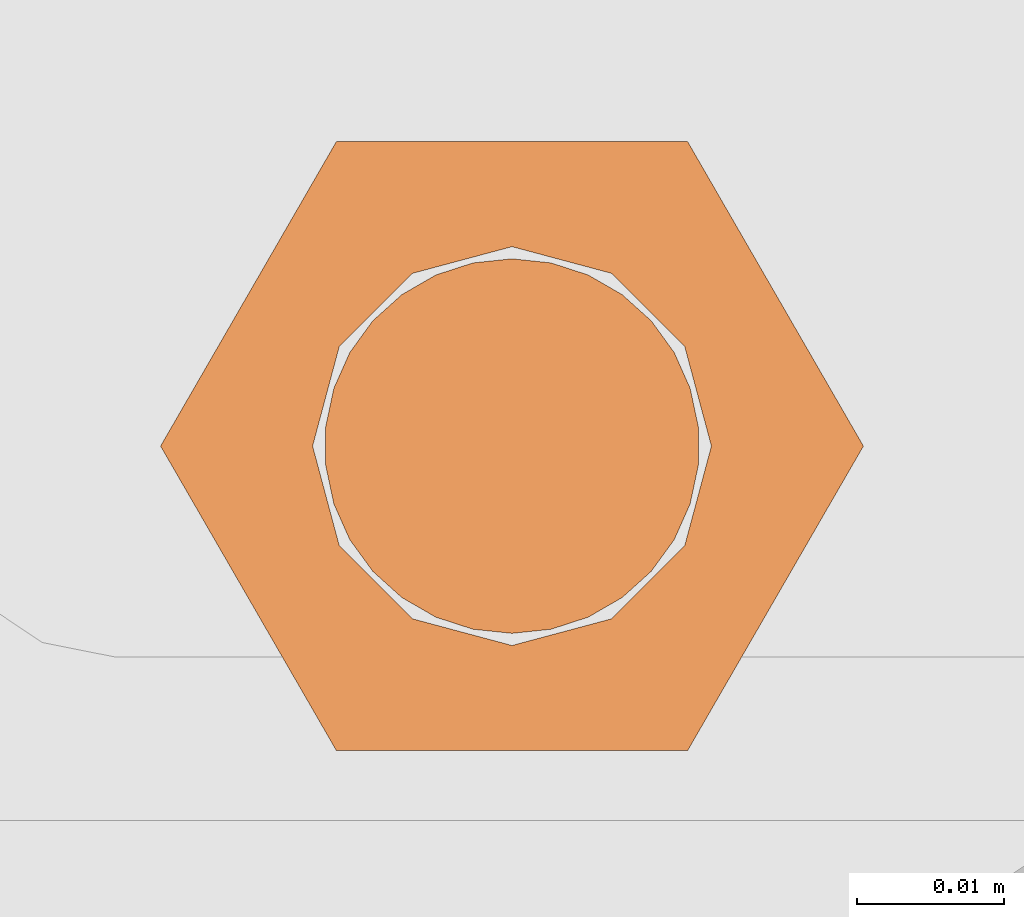
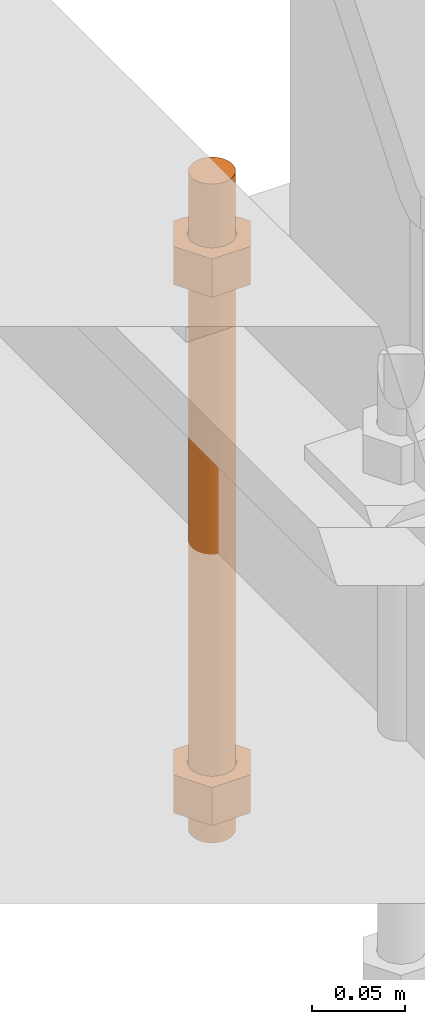
# One storey, part 31 of 89: 1 proxy.
"""IFC4 building model written with IfcOpenShell, lengths in feet."""

from ifc_helpers import new_model, entity, si_unit, converted_unit, derived_unit, direction, frame, origin, place, context, subcontext, project, spatial, faceted_brep, source, transform, mapped, material, constituent, constituent_set, type_object, type_shapes, element, save


model = new_model("IFC4")

# Units and contexts
model_context = context("Model", 3, precision=0.0001, world=origin(), true_north=direction((6.12303176911189e-17, 1.0)))
body_context = subcontext(model_context, "Body", "Model", "MODEL_VIEW")
ifc_project = project(units=[converted_unit("LENGTHUNIT", "FOOT", entity("IfcRatioMeasure", 0.3048), si_unit("LENGTHUNIT", "METRE"), dimensions=[1, 0, 0, 0, 0, 0, 0]), converted_unit("AREAUNIT", "SQUARE FOOT", entity("IfcRatioMeasure", 0.09290304), si_unit("AREAUNIT", "SQUARE_METRE"), dimensions=[2, 0, 0, 0, 0, 0, 0]), converted_unit("VOLUMEUNIT", "CUBIC FOOT", entity("IfcRatioMeasure", 0.028316846592), si_unit("VOLUMEUNIT", "CUBIC_METRE"), dimensions=[3, 0, 0, 0, 0, 0, 0]), si_unit("PLANEANGLEUNIT", "RADIAN"), si_unit("MASSUNIT", "GRAM", prefix="KILO"), derived_unit("MASSDENSITYUNIT", [(si_unit("MASSUNIT", "GRAM", prefix="KILO"), 1), (si_unit("LENGTHUNIT", "METRE"), -3)]), derived_unit("MOMENTOFINERTIAUNIT", [(si_unit("LENGTHUNIT", "METRE"), 4)]), si_unit("TIMEUNIT", "SECOND"), si_unit("FREQUENCYUNIT", "HERTZ"), si_unit("THERMODYNAMICTEMPERATUREUNIT", "DEGREE_CELSIUS"), derived_unit("THERMALTRANSMITTANCEUNIT", [(si_unit("MASSUNIT", "GRAM", prefix="KILO"), 1), (si_unit("THERMODYNAMICTEMPERATUREUNIT", "KELVIN"), -1), (si_unit("TIMEUNIT", "SECOND"), -3)]), derived_unit("VOLUMETRICFLOWRATEUNIT", [(si_unit("LENGTHUNIT", "METRE"), 3), (si_unit("TIMEUNIT", "SECOND"), -1)]), si_unit("ELECTRICCURRENTUNIT", "AMPERE"), si_unit("ELECTRICVOLTAGEUNIT", "VOLT"), si_unit("POWERUNIT", "WATT"), si_unit("FORCEUNIT", "NEWTON"), si_unit("ILLUMINANCEUNIT", "LUX"), si_unit("LUMINOUSFLUXUNIT", "LUMEN"), si_unit("LUMINOUSINTENSITYUNIT", "CANDELA"), derived_unit("USERDEFINED", [(si_unit("MASSUNIT", "GRAM", prefix="KILO"), -1), (si_unit("LENGTHUNIT", "METRE"), -2), (si_unit("TIMEUNIT", "SECOND"), 3), (si_unit("LUMINOUSFLUXUNIT", "LUMEN"), 1)]), derived_unit("LINEARVELOCITYUNIT", [(si_unit("LENGTHUNIT", "METRE"), 1), (si_unit("TIMEUNIT", "SECOND"), -1)]), si_unit("PRESSUREUNIT", "PASCAL"), derived_unit("USERDEFINED", [(si_unit("LENGTHUNIT", "METRE"), -2), (si_unit("MASSUNIT", "GRAM", prefix="KILO"), 1), (si_unit("TIMEUNIT", "SECOND"), -2)]), derived_unit("LINEARFORCEUNIT", [(si_unit("MASSUNIT", "GRAM", prefix="KILO"), 1), (si_unit("LENGTHUNIT", "METRE"), 1), (si_unit("TIMEUNIT", "SECOND"), -2), (si_unit("LENGTHUNIT", "METRE"), -1)]), derived_unit("PLANARFORCEUNIT", [(si_unit("MASSUNIT", "GRAM", prefix="KILO"), 1), (si_unit("LENGTHUNIT", "METRE"), 1), (si_unit("TIMEUNIT", "SECOND"), -2), (si_unit("LENGTHUNIT", "METRE"), -2)])], contexts=[model_context])

# Site, building, storey
site_placement = place(None, origin())
site = spatial("IfcSite", under=ifc_project, at=site_placement, CompositionType="ELEMENT")
building_placement = place(site_placement, frame((-472.238160486, -49.138065117, 0.0)))
building = spatial("IfcBuilding", under=site, at=building_placement, CompositionType="ELEMENT")
storey_placement = place(building_placement, origin())
storey = spatial("IfcBuildingStorey", under=building, at=storey_placement, Name="Level 1", CompositionType="ELEMENT", Elevation=0.0)

# Proxy
ifc_material_1 = material(Name="Color 7721", Category="Materials")
ifc_constituent_1 = constituent(ifc_material_1, Name="Color 7721", Category="Materials")
ifc_material_2 = material(Name="Color 7720", Category="Materials")
ifc_constituent_2 = constituent(ifc_material_2, Name="Color 7720", Category="Materials")
ifc_constituent_set = constituent_set(constituents=[ifc_constituent_1, ifc_constituent_2])
building_element_proxy_type = type_object("IfcBuildingElementProxyType", Name="rb2", PredefinedType="NOTDEFINED", material=ifc_material_1)
shared_shape = source(origin(), body_context, "Body", "Brep", [
    faceted_brep([(0.122545547339286, 0.0677083333333712, 0.0626666666666664), (0.156365697905557, 0.0677083333333712, 0.0626666666666664), (0.11727427342916, 0.135416666666742, 0.0626666666666664), (0.0390914244764247, 0.135416666666742, 0.0626666666666664), (0.0, 0.0677083333333712, 0.0626666666666664), (0.0338201505662994, 0.0677083333333712, 0.0626666666666664), (0.0397636251696838, 0.089889682526632, 0.0626666666666664), (0.0560014997595601, 0.106127557116452, 0.0626666666666664), (0.0781828489527925, 0.112071031719893, 0.0626666666666664), (0.100364198146025, 0.106127557116452, 0.0626666666666664), (0.116602072735901, 0.089889682526632, 0.0626666666666664), (0.11727427342916, 0.0, 0.0626666666666664), (0.0390914244764247, 0.0, 0.0626666666666664), (0.0397636251696838, 0.0455269841401105, 0.0626666666666664), (0.0560014997595601, 0.029289109550291, 0.0626666666666664), (0.0781828489527925, 0.0233456349468497, 0.0626666666666664), (0.100364198146025, 0.029289109550291, 0.0626666666666664), (0.116602072735901, 0.0455269841401105, 0.0626666666666664), (0.0, 0.0677083333333712, 0.144697916666667), (0.0390914244763962, 0.135416666666742, 0.144697916666667), (0.11727427342916, 0.135416666666742, 0.144697916666667), (0.156365697905528, 0.0677083333333712, 0.144697916666667), (0.117274273429189, 0.0, 0.144697916666667), (0.0390914244764247, 0.0, 0.144697916666667), (0.122545547339286, 0.0677083333333712, 0.144697916666666), (0.0338201505662994, 0.0677083333333712, 0.144697916666666), (0.0397636251696838, 0.0455269841401105, 0.144697916666666), (0.0560014997595601, 0.029289109550291, 0.144697916666666), (0.0781828489527925, 0.0233456349468497, 0.144697916666666), (0.100364198146025, 0.029289109550291, 0.144697916666666), (0.116602072735901, 0.0455269841401105, 0.144697916666666), (0.0397636251696838, 0.089889682526632, 0.144697916666666), (0.0560014997595601, 0.106127557116452, 0.144697916666666), (0.0781828489527925, 0.112071031719893, 0.144697916666666), (0.100364198146025, 0.106127557116452, 0.144697916666666), (0.116602072735901, 0.089889682526632, 0.144697916666666)], [[[0, 1, 2, 3, 4, 5, 6, 7, 8, 9, 10]], [[1, 11, 12, 4, 5, 13, 14, 15, 16, 17, 0]], [[4, 18, 19, 3]], [[3, 19, 20, 2]], [[2, 20, 21, 1]], [[1, 21, 22, 11]], [[11, 22, 23, 12]], [[12, 23, 18, 4]], [[24, 21, 22, 23, 18, 25, 26, 27, 28, 29, 30]], [[21, 20, 19, 18, 25, 31, 32, 33, 34, 35, 24]], [[25, 5, 6, 31]], [[31, 6, 7, 32]], [[32, 7, 8, 33]], [[33, 8, 9, 34]], [[34, 9, 10, 35]], [[35, 10, 0, 24]], [[24, 0, 17, 30]], [[30, 17, 16, 29]], [[29, 16, 15, 28]], [[28, 15, 14, 27]], [[27, 14, 13, 26]], [[26, 13, 5, 25]]]),
    faceted_brep([(0.0338201505662994, 0.0677083333333712, 1.28108333333333), (0.0, 0.0677083333333712, 1.28108333333333), (0.0390914244764247, 0.135416666666742, 1.28108333333333), (0.11727427342916, 0.135416666666742, 1.28108333333333), (0.156365697905557, 0.0677083333333712, 1.28108333333333), (0.122545547339286, 0.0677083333333712, 1.28108333333333), (0.116602072735901, 0.089889682526632, 1.28108333333333), (0.100364198146025, 0.106127557116452, 1.28108333333333), (0.0781828489527925, 0.112071031719893, 1.28108333333333), (0.0560014997595601, 0.106127557116452, 1.28108333333333), (0.0397636251696838, 0.089889682526632, 1.28108333333333), (0.0390914244764247, 0.0, 1.28108333333333), (0.11727427342916, 0.0, 1.28108333333333), (0.116602072735901, 0.0455269841401105, 1.28108333333333), (0.100364198146025, 0.029289109550291, 1.28108333333333), (0.0781828489527925, 0.0233456349468497, 1.28108333333333), (0.0560014997595601, 0.029289109550291, 1.28108333333333), (0.0397636251696838, 0.0455269841401105, 1.28108333333333), (0.156365697905585, 0.0677083333333712, 1.19905208333333), (0.117274273429189, 0.135416666666742, 1.19905208333333), (0.0390914244764247, 0.135416666666742, 1.19905208333333), (0.0, 0.0677083333333712, 1.19905208333333), (0.0390914244763962, 0.0, 1.19905208333333), (0.11727427342916, 0.0, 1.19905208333333), (0.0338201505662994, 0.0677083333333712, 1.19905208333333), (0.122545547339286, 0.0677083333333712, 1.19905208333333), (0.116602072735901, 0.0455269841401105, 1.19905208333333), (0.100364198146025, 0.029289109550291, 1.19905208333333), (0.0781828489527925, 0.0233456349468497, 1.19905208333333), (0.0560014997595601, 0.029289109550291, 1.19905208333333), (0.0397636251696838, 0.0455269841401105, 1.19905208333333), (0.116602072735901, 0.089889682526632, 1.19905208333333), (0.100364198146025, 0.106127557116452, 1.19905208333333), (0.0781828489527925, 0.112071031719893, 1.19905208333333), (0.0560014997595601, 0.106127557116452, 1.19905208333333), (0.0397636251696838, 0.089889682526632, 1.19905208333333)], [[[0, 1, 2, 3, 4, 5, 6, 7, 8, 9, 10]], [[1, 11, 12, 4, 5, 13, 14, 15, 16, 17, 0]], [[4, 18, 19, 3]], [[3, 19, 20, 2]], [[2, 20, 21, 1]], [[1, 21, 22, 11]], [[11, 22, 23, 12]], [[12, 23, 18, 4]], [[24, 21, 22, 23, 18, 25, 26, 27, 28, 29, 30]], [[21, 20, 19, 18, 25, 31, 32, 33, 34, 35, 24]], [[25, 5, 6, 31]], [[31, 6, 7, 32]], [[32, 7, 8, 33]], [[33, 8, 9, 34]], [[34, 9, 10, 35]], [[35, 10, 0, 24]], [[24, 0, 17, 30]], [[30, 17, 16, 29]], [[29, 16, 15, 28]], [[28, 15, 14, 27]], [[27, 14, 13, 26]], [[26, 13, 5, 25]]]),
    faceted_brep([(0.0781828489527925, 0.0260416666667425, 0.0), (0.0695198618353743, 0.0269521833027966, 0.0), (0.0612354888246216, 0.029643939264929, 0.0), (0.0536917967739328, 0.0339992919010683, 0.0), (0.0472184812245757, 0.0398278914017283, 0.0), (0.0420984571284464, 0.046875, 0.0), (0.0385554941071575, 0.0548326252344395, 0.0), (0.0367444366457903, 0.0633529806972319, 0.0), (0.0367444366457903, 0.0720636859695105, 0.0), (0.0385554941071575, 0.0805840414323029, 0.0), (0.0420984571284464, 0.0885416666667425, 0.0), (0.0472184812245757, 0.0955887752650142, 0.0), (0.0536917967739328, 0.101417374765674, 0.0), (0.0612354888246216, 0.105772727401813, 0.0), (0.0695198618353743, 0.108464483363946, 0.0), (0.0781828489527925, 0.109375, 0.0), (0.0868458360702107, 0.108464483363946, 0.0), (0.0951302090809634, 0.105772727401813, 0.0), (0.102673901131652, 0.101417374765674, 0.0), (0.109147216681009, 0.0955887752650142, 0.0), (0.114267240777139, 0.0885416666667425, 0.0), (0.117810203798427, 0.0805840414323029, 0.0), (0.119621261259795, 0.0720636859695105, 0.0), (0.119621261259795, 0.0633529806972319, 0.0), (0.117810203798427, 0.0548326252344395, 0.0), (0.114267240777139, 0.046875, 0.0), (0.109147216681009, 0.0398278914017283, 0.0), (0.102673901131652, 0.0339992919010683, 0.0), (0.0951302090809634, 0.029643939264929, 0.0), (0.0868458360702107, 0.0269521833027966, 0.0), (0.0868458360702107, 0.0269521833027966, 1.41666666666667), (0.0951302090809634, 0.029643939264929, 1.41666666666667), (0.102673901131652, 0.0339992919010683, 1.41666666666667), (0.109147216681009, 0.0398278914017283, 1.41666666666667), (0.114267240777139, 0.046875, 1.41666666666667), (0.117810203798427, 0.0548326252344395, 1.41666666666667), (0.119621261259795, 0.0633529806972319, 1.41666666666667), (0.119621261259795, 0.0720636859695105, 1.41666666666667), (0.117810203798427, 0.0805840414323029, 1.41666666666667), (0.114267240777139, 0.0885416666667425, 1.41666666666667), (0.109147216681009, 0.0955887752650142, 1.41666666666667), (0.102673901131652, 0.101417374765674, 1.41666666666667), (0.0951302090809634, 0.105772727401813, 1.41666666666667), (0.0868458360702107, 0.108464483363946, 1.41666666666667), (0.0781828489527925, 0.109375, 1.41666666666667), (0.0695198618353743, 0.108464483363946, 1.41666666666667), (0.0612354888246216, 0.105772727401813, 1.41666666666667), (0.0536917967739328, 0.101417374765674, 1.41666666666667), (0.0472184812245757, 0.0955887752650142, 1.41666666666667), (0.0420984571284464, 0.0885416666667425, 1.41666666666667), (0.0385554941071575, 0.0805840414323029, 1.41666666666667), (0.0367444366457903, 0.0720636859695105, 1.41666666666667), (0.0367444366457903, 0.0633529806972319, 1.41666666666667), (0.0385554941071575, 0.0548326252344395, 1.41666666666667), (0.0420984571284464, 0.046875, 1.41666666666667), (0.0472184812245757, 0.0398278914017283, 1.41666666666667), (0.0536917967739328, 0.0339992919010683, 1.41666666666667), (0.0612354888246216, 0.029643939264929, 1.41666666666667), (0.0695198618353743, 0.0269521833027966, 1.41666666666667), (0.0781828489527925, 0.0260416666667425, 1.41666666666667), (0.0695198618353743, 0.0269521833027966, 0.25), (0.0781828489527925, 0.0260416666667425, 0.25), (0.0612354888246216, 0.029643939264929, 0.25), (0.0536917967739328, 0.0339992919010683, 0.25), (0.0472184812246041, 0.0398278914017283, 0.25), (0.0420984571284464, 0.046875, 0.25), (0.0385554941071575, 0.0548326252344395, 0.25), (0.0367444366458187, 0.0633529806972319, 0.25), (0.0367444366457903, 0.0720636859695105, 0.25), (0.0385554941071575, 0.0805840414323029, 0.25), (0.0420984571284464, 0.0885416666667425, 0.25), (0.0472184812245757, 0.0955887752650142, 0.25), (0.0536917967739043, 0.101417374765674, 0.25), (0.0612354888246216, 0.105772727401813, 0.25), (0.0695198618353743, 0.108464483363946, 0.25), (0.0781828489527925, 0.109375, 0.25), (0.0868458360702107, 0.108464483363946, 0.25), (0.0951302090809634, 0.105772727401813, 0.25), (0.102673901131652, 0.101417374765674, 0.25), (0.109147216680981, 0.0955887752650142, 0.25), (0.114267240777139, 0.0885416666667425, 0.25), (0.117810203798427, 0.0805840414323029, 0.25), (0.119621261259766, 0.0720636859695105, 0.25), (0.119621261259795, 0.0633529806972319, 0.25), (0.117810203798427, 0.0548326252344395, 0.25), (0.114267240777139, 0.046875, 0.25), (0.109147216681009, 0.0398278914017283, 0.25), (0.102673901131681, 0.0339992919010683, 0.25), (0.0951302090809634, 0.029643939264929, 0.25), (0.0868458360702107, 0.0269521833027966, 0.25), (0.0695198618353743, 0.0269521833027966, 0.916666666666667), (0.0781828489527925, 0.0260416666667425, 0.916666666666667), (0.0612354888246216, 0.029643939264929, 0.916666666666667), (0.0536917967739328, 0.0339992919010683, 0.916666666666667), (0.0472184812246041, 0.0398278914017283, 0.916666666666667), (0.0420984571284464, 0.046875, 0.916666666666667), (0.0385554941071575, 0.0548326252344395, 0.916666666666667), (0.0367444366458187, 0.0633529806972319, 0.916666666666667), (0.0367444366457903, 0.0720636859695105, 0.916666666666667), (0.0385554941071575, 0.0805840414323029, 0.916666666666667), (0.0420984571284464, 0.0885416666667425, 0.916666666666667), (0.0472184812245757, 0.0955887752650142, 0.916666666666667), (0.0536917967739043, 0.101417374765674, 0.916666666666667), (0.0612354888246216, 0.105772727401813, 0.916666666666667), (0.0695198618353743, 0.108464483363946, 0.916666666666667), (0.0781828489527925, 0.109375, 0.916666666666667), (0.0868458360702107, 0.108464483363946, 0.916666666666667), (0.0951302090809634, 0.105772727401813, 0.916666666666667), (0.102673901131652, 0.101417374765674, 0.916666666666667), (0.109147216680981, 0.0955887752650142, 0.916666666666667), (0.114267240777139, 0.0885416666667425, 0.916666666666667), (0.117810203798427, 0.0805840414323029, 0.916666666666667), (0.119621261259766, 0.0720636859695105, 0.916666666666667), (0.119621261259795, 0.0633529806972319, 0.916666666666667), (0.117810203798427, 0.0548326252344395, 0.916666666666667), (0.114267240777139, 0.046875, 0.916666666666667), (0.109147216681009, 0.0398278914017283, 0.916666666666667), (0.102673901131681, 0.0339992919010683, 0.916666666666667), (0.0951302090809634, 0.029643939264929, 0.916666666666667), (0.0868458360702107, 0.0269521833027966, 0.916666666666667)], [[[0, 1, 2, 3, 4, 5, 6, 7, 8, 9, 10, 11, 12, 13, 14, 15, 16, 17, 18, 19, 20, 21, 22, 23, 24, 25, 26, 27, 28, 29]], [[30, 31, 32, 33, 34, 35, 36, 37, 38, 39, 40, 41, 42, 43, 44, 45, 46, 47, 48, 49, 50, 51, 52, 53, 54, 55, 56, 57, 58, 59]], [[60, 1, 0, 61]], [[62, 2, 1, 60]], [[63, 3, 2, 62]], [[64, 4, 3, 63]], [[65, 5, 4, 64]], [[66, 6, 5, 65]], [[67, 7, 6, 66]], [[68, 8, 7, 67]], [[69, 9, 8, 68]], [[70, 10, 9, 69]], [[71, 11, 10, 70]], [[72, 12, 11, 71]], [[73, 13, 12, 72]], [[74, 14, 13, 73]], [[75, 15, 14, 74]], [[76, 16, 15, 75]], [[77, 17, 16, 76]], [[78, 18, 17, 77]], [[79, 19, 18, 78]], [[80, 20, 19, 79]], [[81, 21, 20, 80]], [[82, 22, 21, 81]], [[83, 23, 22, 82]], [[84, 24, 23, 83]], [[85, 25, 24, 84]], [[86, 26, 25, 85]], [[87, 27, 26, 86]], [[88, 28, 27, 87]], [[89, 29, 28, 88]], [[61, 0, 29, 89]], [[90, 60, 61, 91]], [[92, 62, 60, 90]], [[93, 63, 62, 92]], [[94, 64, 63, 93]], [[95, 65, 64, 94]], [[96, 66, 65, 95]], [[97, 67, 66, 96]], [[98, 68, 67, 97]], [[99, 69, 68, 98]], [[100, 70, 69, 99]], [[101, 71, 70, 100]], [[102, 72, 71, 101]], [[103, 73, 72, 102]], [[104, 74, 73, 103]], [[105, 75, 74, 104]], [[106, 76, 75, 105]], [[107, 77, 76, 106]], [[108, 78, 77, 107]], [[109, 79, 78, 108]], [[110, 80, 79, 109]], [[111, 81, 80, 110]], [[112, 82, 81, 111]], [[113, 83, 82, 112]], [[114, 84, 83, 113]], [[115, 85, 84, 114]], [[116, 86, 85, 115]], [[117, 87, 86, 116]], [[118, 88, 87, 117]], [[119, 89, 88, 118]], [[91, 61, 89, 119]], [[58, 90, 91, 59]], [[57, 92, 90, 58]], [[56, 93, 92, 57]], [[55, 94, 93, 56]], [[54, 95, 94, 55]], [[53, 96, 95, 54]], [[52, 97, 96, 53]], [[51, 98, 97, 52]], [[50, 99, 98, 51]], [[49, 100, 99, 50]], [[48, 101, 100, 49]], [[47, 102, 101, 48]], [[46, 103, 102, 47]], [[45, 104, 103, 46]], [[44, 105, 104, 45]], [[43, 106, 105, 44]], [[42, 107, 106, 43]], [[41, 108, 107, 42]], [[40, 109, 108, 41]], [[39, 110, 109, 40]], [[38, 111, 110, 39]], [[37, 112, 111, 38]], [[36, 113, 112, 37]], [[35, 114, 113, 36]], [[34, 115, 114, 35]], [[33, 116, 115, 34]], [[32, 117, 116, 33]], [[31, 118, 117, 32]], [[30, 119, 118, 31]], [[59, 91, 119, 30]]]),
])
type_shapes(building_element_proxy_type, [shared_shape])
proxy_placement = place(building_placement, frame((199.588483817714, 1009.765625, -1.45833333333333)))
element("IfcBuildingElementProxy", 1, at=proxy_placement, inside=storey, type_object=building_element_proxy_type, material=ifc_constituent_set, Name="rb2 354:rb2 354", ObjectType="rb2 354:rb2 354", PredefinedType="NOTDEFINED", context=body_context, shape_type="MappedRepresentation", body=[
    mapped(shared_shape, transform((0.0, 0.0, 0.0), scale=1.0)),
])

save(model, "model.ifc")
